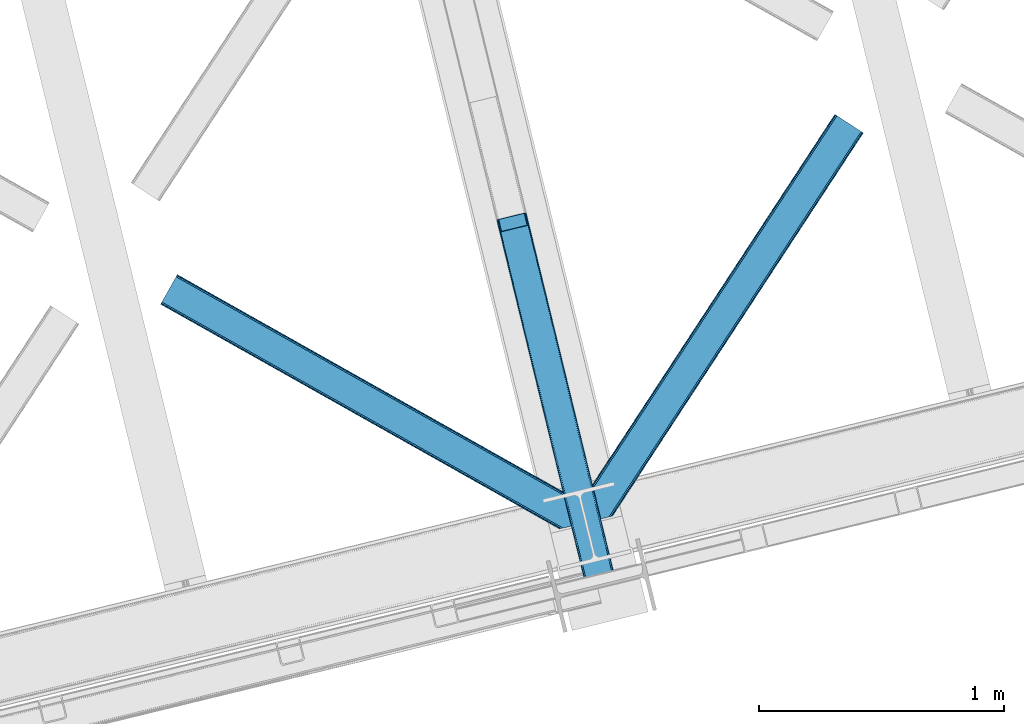
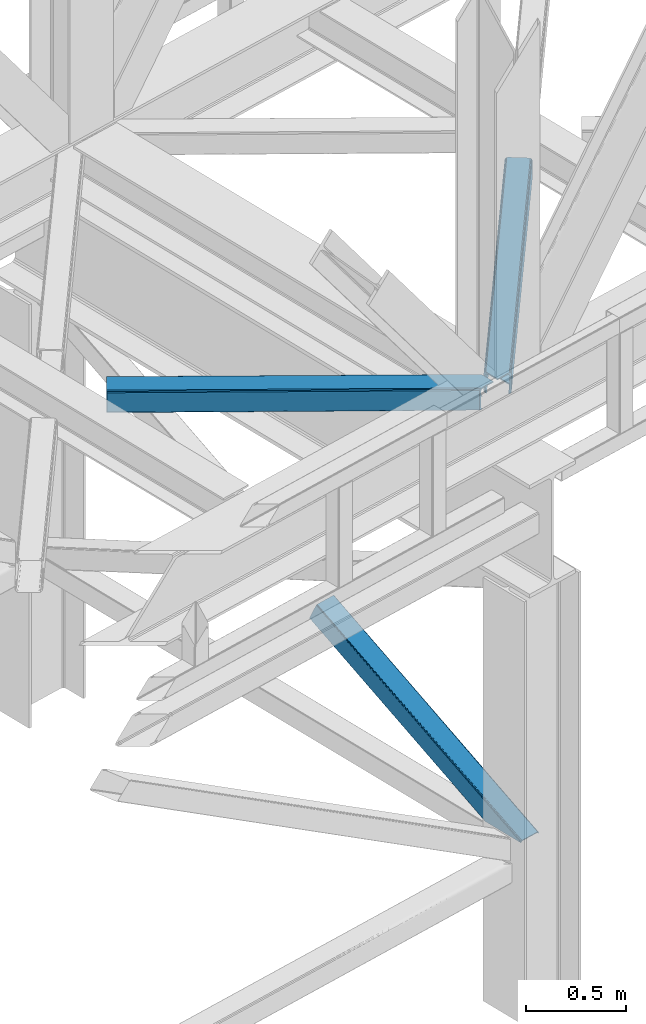
# One storey, part 51 of 92: 3 members.
"""IFC4 building model written with IfcOpenShell, lengths in millimetres."""

from ifc_helpers import new_model, entity, si_unit, converted_unit, derived_unit, direction, frame, origin, place, context, subcontext, project, spatial, triangles, polygons, type_object, element, save


model = new_model("IFC4")

# Units and contexts
model_context = context("Model", 3, precision=0.01, world=origin(), true_north=direction((6.12303176911189e-17, 1.0)))
plan_context = context("Plan", 3, precision=0.01, world=origin(), true_north=direction((6.12303176911189e-17, 1.0)))
body_context = subcontext(model_context, "Body", "Model", "MODEL_VIEW")
ifc_project = project(units=[si_unit("LENGTHUNIT", "METRE", prefix="MILLI"), si_unit("AREAUNIT", "SQUARE_METRE"), si_unit("VOLUMEUNIT", "CUBIC_METRE"), converted_unit("PLANEANGLEUNIT", "DEGREE", entity("IfcRatioMeasure", 0.0174532925199433), si_unit("PLANEANGLEUNIT", "RADIAN"), dimensions=[0, 0, 0, 0, 0, 0, 0]), si_unit("MASSUNIT", "GRAM", prefix="KILO"), derived_unit("MASSDENSITYUNIT", [(si_unit("MASSUNIT", "GRAM", prefix="KILO"), 1), (si_unit("LENGTHUNIT", "METRE"), -3)]), derived_unit("MOMENTOFINERTIAUNIT", [(si_unit("LENGTHUNIT", "METRE"), 4)]), si_unit("TIMEUNIT", "SECOND"), si_unit("FREQUENCYUNIT", "HERTZ"), si_unit("THERMODYNAMICTEMPERATUREUNIT", "DEGREE_CELSIUS"), derived_unit("THERMALTRANSMITTANCEUNIT", [(si_unit("MASSUNIT", "GRAM", prefix="KILO"), 1), (si_unit("THERMODYNAMICTEMPERATUREUNIT", "KELVIN"), -1), (si_unit("TIMEUNIT", "SECOND"), -3)]), derived_unit("VOLUMETRICFLOWRATEUNIT", [(si_unit("LENGTHUNIT", "METRE"), 3), (si_unit("TIMEUNIT", "SECOND"), -1)]), derived_unit("MASSFLOWRATEUNIT", [(si_unit("MASSUNIT", "GRAM", prefix="KILO"), 1), (si_unit("TIMEUNIT", "SECOND"), -1)]), derived_unit("ROTATIONALFREQUENCYUNIT", [(si_unit("TIMEUNIT", "SECOND"), -1)]), si_unit("ELECTRICCURRENTUNIT", "AMPERE"), si_unit("ELECTRICVOLTAGEUNIT", "VOLT"), si_unit("POWERUNIT", "WATT"), si_unit("FORCEUNIT", "NEWTON", prefix="KILO"), si_unit("ILLUMINANCEUNIT", "LUX"), si_unit("LUMINOUSFLUXUNIT", "LUMEN"), si_unit("LUMINOUSINTENSITYUNIT", "CANDELA"), derived_unit("USERDEFINED", [(si_unit("MASSUNIT", "GRAM", prefix="KILO"), -1), (si_unit("LENGTHUNIT", "METRE"), -2), (si_unit("TIMEUNIT", "SECOND"), 3), (si_unit("LUMINOUSFLUXUNIT", "LUMEN"), 1)]), derived_unit("LINEARVELOCITYUNIT", [(si_unit("LENGTHUNIT", "METRE"), 1), (si_unit("TIMEUNIT", "SECOND"), -1)]), si_unit("PRESSUREUNIT", "PASCAL"), derived_unit("USERDEFINED", [(si_unit("LENGTHUNIT", "METRE"), -2), (si_unit("MASSUNIT", "GRAM", prefix="KILO"), 1), (si_unit("TIMEUNIT", "SECOND"), -2)]), derived_unit("LINEARFORCEUNIT", [(si_unit("MASSUNIT", "GRAM", prefix="KILO"), 1), (si_unit("LENGTHUNIT", "METRE"), 1), (si_unit("TIMEUNIT", "SECOND"), -2), (si_unit("LENGTHUNIT", "METRE"), -1)]), derived_unit("PLANARFORCEUNIT", [(si_unit("MASSUNIT", "GRAM", prefix="KILO"), 1), (si_unit("LENGTHUNIT", "METRE"), 1), (si_unit("TIMEUNIT", "SECOND"), -2), (si_unit("LENGTHUNIT", "METRE"), -2)])], contexts=[model_context, plan_context])

# Site, building, storey
site_placement = place(None, origin())
site = spatial("IfcSite", under=ifc_project, at=site_placement, CompositionType="ELEMENT")
building_placement = place(site_placement, origin())
building = spatial("IfcBuilding", under=site, at=building_placement, CompositionType="ELEMENT")
storey_placement = place(building_placement, frame((0.0, 0.0, 15900.0)))
storey = spatial("IfcBuildingStorey", under=building, at=storey_placement, Name="05", CompositionType="ELEMENT", Elevation=15900.0)

# Members
member_type_1 = type_object("IfcMemberType", PredefinedType="BRACE")
member_1_placement = place(storey_placement, frame((-36161.51, 8634.38, 970.5)))
element("IfcMember", 1, at=member_1_placement, inside=storey, type_object=member_type_1, ObjectType="Steel Vertical Brace", PredefinedType="BRACE", context=body_context, shape_type="Tessellation", body=[
    polygons([(310.156875969815, 236.659699185642, 1.04388391264365e-09), (309.042346364978, 243.803283956976, 1.04388391264365e-09), (4.57230123623604, 1492.85694714149, 603.530503671961), (4.2887644560269, 1491.44877039324, 606.301796687595), (309.280773738945, 250.147759710232, 1.04388391264365e-09), (5.99595206162693, 1494.33917875156, 601.181114896124), (310.835859685345, 254.727237524779, 1.05038111541944e-09), (8.34297899943531, 1495.6698088973, 599.611303503947), (313.47085646575, 256.844533416439, 1.04171817838505e-09), (11.256068474249, 1496.64626120118, 599.060059049496), (366.444630080972, 5.74560241384962, 1.00706643024751e-09), (14.4533090982431, 1449.74988433501, 697.72873436856), (411.597614338024, 280.763968808462, 1.04171817838505e-09), (109.382826346531, 1520.5656965932, 599.060059049498), (425.485457020332, 274.460769180909, 1.03522097560926e-09), (485.172065028795, 29.6032616237788, 9.24768528420827e-10), (481.013627176891, 28.5895984014809, 9.24768528420827e-10), (480.116220883526, 33.4542552937189, 9.72414682109957e-10), (423.82846677236, 264.368352065509, 1.03305524135067e-09), (421.530657217855, 271.223499830256, 1.03522097560926e-09), (418.399388388628, 276.746576483304, 1.03738670986786e-09), (414.911367578924, 280.096743671032, 1.04171817838505e-09), (367.88649561307, 1.0136632218215, 9.29099996938021e-10), (363.728057761106, 2.16573425859679e-12, 5.76085312786745e-10), (304.041449752642, 244.857507557118, 1.03522097560926e-09), (302.926920147815, 252.001092328461, 1.04171817838505e-09), (303.165347521768, 258.345568081721, 1.03738670986786e-09), (304.720433468177, 262.925045896267, 1.04604964690225e-09), (307.355430248578, 265.042341787915, 1.04388391264365e-09), (413.254604585991, 290.856385923861, 1.04604964690225e-09), (416.568357826891, 290.189160786438, 1.04604964690225e-09), (420.056378636596, 286.838993598711, 1.04171817838505e-09), (423.187647465814, 281.315916945663, 1.04171817838505e-09), (112.418486893023, 1521.03931504355, 599.611303503942), (115.114566711319, 1520.93799552464, 601.181114896124), (117.060612089108, 1520.27716301477, 603.530503671961), (117.960355258563, 1519.15742327311, 606.301796687595), (128.124899900792, 1477.45853721488, 697.72873436856), (127.841363120579, 1476.05036046663, 700.500027384193), (126.417712295192, 1474.56812885655, 702.849416160034), (124.070685357384, 1473.23749871082, 704.419227552215), (121.15759588257, 1472.26104640693, 704.970472006657), (23.0308380102795, 1448.34161101491, 704.970472006657), (19.9951774637964, 1447.86799256457, 704.419227552218), (17.2990976455005, 1447.96931208348, 702.849416160031), (15.3530522677154, 1448.63014459335, 700.500027384193), (112.866478355636, 1523.16444199718, 595.439190230451), (6.96730401822207, 1497.35039786123, 595.439190230448), (4.05421454341707, 1496.37394555734, 595.990434684895), (1.70718760560436, 1495.04331541162, 597.56024607707), (0.28353678022213, 1493.56108380154, 599.909634852913), (0.0, 1492.15290705329, 602.680927868548), (10.9696570891299, 1447.15113893104, 701.349603187608), (11.8694002585979, 1446.03139918938, 704.120896203242), (13.8154456363916, 1445.37056667951, 706.470284979081), (16.5115254546875, 1445.2692471606, 708.040096371263), (19.5471860011707, 1445.74286561094, 708.591340825705), (125.446360338589, 1471.55690974689, 708.591340825705), (128.359449813402, 1472.53336205077, 708.040096371265), (130.706476751211, 1473.8639921965, 706.470284979079), (132.130127576593, 1475.34622380658, 704.120896203244), (132.413664356815, 1476.75440055483, 701.349603187608), (121.44400726769, 1521.75616867708, 602.680927868548), (120.544264098226, 1522.87590841874, 599.909634852913), (118.598218720428, 1523.53674092861, 597.560246077077), (115.902138902128, 1523.63806044752, 595.990434684897), (375.386682458807, 2.84191311588486, 6.51916727653314), (372.638718264457, 2.17206777061844, 5.2249222388966), (369.890754070107, 1.50222242536393, 3.93067720123624), (368.37332664802, 1.13233343716275, 0.954754934343811), (480.407239661998, 28.4417850297788, 0.783330976602792), (478.425418155208, 27.9586950702373, 3.34344663920135), (476.487815341744, 27.4863838850221, 5.84644062407408), (473.513440331089, 26.761348507908, 6.51916727653314), (485.1720650288, 29.6032616237626, 2.10033831597304), (484.033820990584, 29.325802597071, 5.22492223888794), (482.895576952364, 29.0483435703718, 8.34950616180717), (480.147612758018, 28.3784982251097, 9.64375119945237), (477.399648563664, 27.7086528798498, 10.9379962370932), (371.500474226237, 1.89460874392252, 10.9379962370954), (368.752510031891, 1.22476339866151, 9.64375119945237), (366.004545837554, 0.55491805340375, 8.34950616180934), (364.866301799321, 0.277459026700251, 5.2249222388901), (363.728057761106, 2.16573425859679e-12, 2.10033831597304)], [[[1, 2, 3, 4]], [[2, 5, 6, 3]], [[5, 7, 8, 6]], [[7, 9, 10, 8]], [[11, 1, 4, 12]], [[9, 13, 14, 10]], [[15, 16, 17, 18, 19, 20, 21, 22, 13, 9, 7, 5, 2, 1, 11, 23, 24, 25, 26, 27, 28, 29, 30, 31, 32, 33]], [[47, 48, 49, 50, 51, 52, 53, 54, 55, 56, 57, 58, 59, 60, 61, 62, 63, 64, 65, 66], [10, 14, 34, 35, 36, 37, 38, 39, 40, 41, 42, 43, 44, 45, 46, 12, 4, 3, 6, 8]], [[13, 22, 34, 14]], [[22, 21, 35, 34]], [[21, 20, 36, 35]], [[20, 19, 37, 36]], [[19, 18, 38, 37]], [[44, 67, 68]], [[45, 68, 69]], [[46, 69, 70]], [[46, 11, 12]], [[11, 70, 23]], [[11, 46, 70]], [[69, 46, 45]], [[68, 45, 44]], [[67, 44, 43]], [[71, 18, 17]], [[39, 72, 40]], [[40, 73, 41]], [[73, 74, 42, 41]], [[73, 40, 72]], [[72, 39, 71]], [[39, 18, 71]], [[18, 39, 38]], [[42, 74, 67, 43]], [[16, 75, 76, 77, 78, 79, 80, 81, 82, 83, 84, 24, 23, 70, 69, 68, 67, 74, 73, 72, 71, 17]], [[29, 28, 49, 48]], [[28, 27, 50, 49]], [[27, 26, 51, 50]], [[26, 25, 52, 51]], [[47, 30, 29, 48]], [[15, 33, 64, 63]], [[33, 32, 65, 64]], [[32, 31, 66, 65]], [[31, 30, 47, 66]], [[24, 84, 53, 52, 25]], [[75, 16, 15, 63, 62]], [[53, 83, 54]], [[54, 82, 55]], [[55, 81, 56]], [[56, 80, 57]], [[80, 56, 81]], [[81, 55, 82]], [[82, 54, 83]], [[83, 53, 84]], [[80, 79, 58, 57]], [[59, 79, 78]], [[60, 78, 77]], [[61, 77, 76]], [[62, 76, 75]], [[76, 62, 61]], [[77, 61, 60]], [[78, 60, 59]], [[79, 59, 58]]], closed=True),
])
member_type_2 = type_object("IfcMemberType", PredefinedType="BRACE")
member_2_placement = place(storey_placement, frame((-35805.58, 8895.62, 3511.0)))
element("IfcMember", 2, at=member_2_placement, inside=storey, type_object=member_type_2, ObjectType="Steel Horizontal Brace", PredefinedType="BRACE", context=body_context, shape_type="Tessellation", body=[
    triangles([(109.770043945318, 259.949830627442, 7.52047119140843), (115.030187988283, 238.365682983398, 7.77510681152489), (114.216284179689, 239.946981811523, 8.3320495605476), (108.809637451173, 259.662638854981, 8.52041015625218), (113.637249755862, 239.859777832031, 8.52041015625218), (112.20710449219, 237.677352905273, 8.52041015625218), (91.0339782714873, 232.516621398925, 8.52041015625218), (109.535174560551, 237.025648498535, 9.50058288574292), (90.2619323730469, 232.328260803222, 9.50058288574292), (5.0206237793027, 77.405158996582, 9.50058288574292), (0.625543212896446, 95.4308029174808, 9.50058288574292), (1046.62216186523, 1651.75382995605, 6.99957275390625), (1041.02017822266, 1655.42221069336, 8.3320495605476), (116.699853515631, 231.514938354492, 6.99957275390625), (1036.26930541993, 1658.53132324219, 12.1260040283232), (3.92999267578125, 81.8752349853512, 12.1260040283232), (1033.09740600587, 1660.61026611328, 17.8035644531265), (2.69983520507958, 86.9220199584961, 17.8035644531265), (1031.98352050781, 1661.34045410156, 24.4996673583992), (2.26962890625146, 88.6940048217766, 24.4996673583992), (1122.7547241211, 1601.90454711914, 6.99957275390625), (146.209680175787, 110.459536743165, 6.99957275390625), (1031.98352050781, 1661.34045410156, 115.501089477541), (2.26962890625146, 88.6940048217766, 115.501089477541), (1033.09740600587, 1660.61026611328, 122.196029663086), (2.69983520507958, 86.9220199584961, 122.196029663086), (1036.26930541993, 1658.53132324219, 127.87475280762), (3.92999267578125, 81.8752349853512, 127.87475280762), (1041.02017822266, 1655.42221069336, 131.667544555665), (5.77174072265916, 74.3227890014641, 131.667544555665), (1046.62216186523, 1651.75382995605, 133.000021362306), (7.94370117187646, 65.4140304565426, 133.000021362306), (1027.24194946289, 1664.44491577148, 10.8028289794929), (0.518572998051241, 95.8714736938473, 10.8691040039084), (0.0, 98.0056457519531, 17.5000946044929), (1035.16472167969, 1659.25686035156, 1.33247680664135), (112.260589599609, 249.73533782959, 1.33247680664135), (110.544415283206, 256.772117614746, 5.59500732422021), (109.077062988283, 259.839372253418, 8.31925964355469), (1030.41384887695, 1662.36597290039, 5.12526855468968), (1040.76670532227, 1655.58847961426, 0.0), (114.430224609379, 240.826579284669, 0.0), (1026.12573852539, 1665.17394104004, 17.5000946044929), (1128.61250610352, 1598.06989746094, 0.0), (148.479309082031, 101.147314453125, 0.0), (150.651269531256, 92.2385559082031, 1.33247680664135), (148.507214355472, 101.029298400879, 8.50064392089917), (152.493017578126, 84.686109924316, 5.12526855468968), (153.346453857426, 81.182254028321, 8.50064392089917), (1026.12573852539, 1665.17394104004, 122.500662231447), (0.0, 98.0056457519531, 122.500662231447), (1040.76670532227, 1655.58847961426, 139.999594116212), (1035.16472167969, 1659.25686035156, 138.667117309571), (3.50211181640771, 83.6350112915043, 138.667117309571), (5.674072265625, 74.7256713867191, 139.999594116212), (1030.41384887695, 1662.36597290039, 134.874325561526), (1.66036376953707, 91.1874572753914, 134.874325561526), (1027.24194946289, 1664.44491577148, 129.197927856447), (0.430206298828125, 96.2336608886726, 129.197927856447), (23.8892395019575, 0.0, 139.999594116212), (23.8892395019575, 0.0, 133.000021362306), (1128.61250610352, 1598.06989746094, 139.999594116212), (93.3338378906265, 16.9280364990227, 139.999594116212), (1122.7547241211, 1601.90454711914, 133.000021362306), (83.3786315917969, 14.5008590698235, 133.000021362306), (1143.2534729004, 1588.48443603516, 122.500662231447), (1142.1372619629, 1589.21346130371, 129.197927856447), (118.225341796875, 22.9951080322262, 122.500662231447), (116.330108642578, 22.5335083007813, 129.197927856447), (1138.96536254883, 1591.29124145508, 134.874325561526), (110.935089111328, 21.2178909301765, 134.874325561526), (1134.2144897461, 1594.40151672363, 138.667117309571), (102.861163330082, 19.2499877929695, 138.667117309571), (1143.2534729004, 1588.48443603516, 17.5000946044929), (118.225341796875, 22.9951080322262, 17.5000946044929), (1142.1372619629, 1589.21346130371, 10.8028289794929), (1133.10758056641, 1595.12589111328, 12.1260040283232), (1136.28180541992, 1593.04811096191, 17.8035644531265), (1137.39569091797, 1592.31792297363, 24.4996673583992), (1138.96536254883, 1591.29124145508, 5.12526855468968), (1134.2144897461, 1594.40151672363, 1.33247680664135), (1128.35903320313, 1598.23616638184, 8.3320495605476), (1133.10758056641, 1595.12589111328, 127.87475280762), (1137.39569091797, 1592.31792297363, 115.501089477541), (1136.28180541992, 1593.04811096191, 122.196029663086), (1128.35903320313, 1598.23616638184, 131.667544555665), (92.9036315917983, 16.8228103637703, 131.667544555665), (100.977557373051, 18.7912948608391, 127.87475280762), (106.372576904301, 20.106330871582, 122.196029663086), (108.267810058598, 20.5685119628906, 115.501089477541), (108.267810058598, 20.5685119628906, 24.4996673583992), (100.977557373051, 18.7912948608391, 12.1260040283232), (115.472021484376, 22.32421875, 9.50058288574292), (106.372576904301, 20.106330871582, 17.8035644531265), (96.1987792968794, 17.6262496948239, 9.50058288574292), (115.944085693365, 22.439328002929, 10.8702667236357), (153.060424804688, 80.2392883300781, 9.00061340332104), (152.776721191411, 79.2969039916989, 9.50058288574292), (148.711853027344, 99.8677413940422, 8.8831787109375), (148.602557373051, 99.023606872559, 9.08781738281323), (148.490936279297, 98.1666824340828, 9.29478149414354), (148.381640625004, 97.3231292724613, 9.50058288574292)], [[1, 2, 3], [4, 5, 6], [6, 7, 4], [7, 6, 8], [8, 9, 7], [9, 8, 10], [10, 11, 9], [12, 13, 3], [3, 2, 12], [2, 14, 12], [15, 16, 8], [8, 13, 15], [8, 5, 13], [16, 10, 8], [8, 6, 5], [15, 17, 18], [18, 16, 15], [17, 19, 20], [20, 18, 17], [21, 12, 14], [14, 22, 21], [19, 23, 20], [24, 20, 23], [23, 25, 24], [26, 24, 25], [25, 27, 26], [28, 26, 27], [27, 29, 28], [30, 28, 29], [29, 31, 30], [32, 30, 31], [33, 34, 35], [36, 37, 38], [33, 4, 9], [33, 1, 39], [9, 34, 33], [9, 11, 34], [4, 7, 9], [40, 38, 1], [1, 33, 40], [38, 40, 36], [36, 41, 37], [42, 37, 41], [35, 43, 33], [41, 44, 42], [45, 42, 44], [14, 42, 22], [37, 2, 38], [2, 37, 42], [38, 2, 1], [42, 14, 2], [22, 42, 45], [46, 47, 45], [47, 46, 48], [45, 47, 22], [48, 49, 47], [50, 43, 35], [35, 51, 50], [52, 53, 54], [54, 55, 52], [53, 56, 57], [57, 54, 53], [56, 58, 59], [59, 57, 56], [58, 50, 51], [51, 59, 58], [28, 57, 26], [30, 32, 55], [32, 60, 55], [32, 61, 60], [54, 30, 55], [28, 54, 57], [16, 11, 10], [28, 30, 54], [51, 35, 20], [24, 26, 51], [24, 51, 20], [57, 59, 26], [26, 59, 51], [35, 18, 20], [18, 11, 16], [11, 18, 34], [35, 34, 18], [62, 55, 63], [62, 52, 55], [55, 60, 63], [64, 32, 31], [32, 64, 65], [61, 32, 65], [66, 67, 68], [69, 68, 67], [67, 70, 69], [71, 69, 70], [70, 72, 71], [73, 71, 72], [72, 62, 73], [63, 73, 62], [74, 66, 75], [68, 75, 66], [76, 77, 78], [79, 66, 74], [76, 78, 74], [76, 80, 77], [78, 79, 74], [77, 80, 81], [21, 44, 41], [44, 82, 81], [82, 44, 21], [82, 77, 81], [67, 83, 70], [84, 66, 79], [66, 85, 67], [85, 66, 84], [67, 85, 83], [62, 64, 52], [72, 70, 83], [83, 86, 72], [86, 64, 62], [62, 72, 86], [15, 36, 40], [41, 12, 21], [41, 13, 12], [13, 41, 36], [15, 13, 36], [19, 43, 50], [33, 17, 15], [40, 33, 15], [17, 33, 43], [19, 17, 43], [53, 27, 56], [52, 64, 31], [31, 29, 52], [29, 27, 53], [53, 52, 29], [58, 56, 27], [50, 23, 19], [25, 50, 58], [50, 25, 23], [25, 58, 27], [64, 86, 87], [87, 65, 64], [86, 83, 88], [88, 87, 86], [83, 85, 89], [89, 88, 83], [85, 84, 90], [90, 89, 85], [84, 79, 90], [91, 90, 79], [89, 68, 69], [87, 73, 63], [60, 65, 63], [65, 60, 61], [65, 87, 63], [88, 73, 87], [88, 89, 71], [71, 73, 88], [69, 71, 89], [91, 75, 68], [92, 93, 94], [89, 90, 68], [92, 95, 93], [91, 94, 75], [90, 91, 68], [96, 75, 94], [94, 93, 96], [76, 74, 75], [49, 80, 97], [98, 97, 80], [49, 48, 80], [76, 96, 98], [98, 80, 76], [96, 93, 98], [44, 81, 45], [46, 45, 81], [81, 80, 46], [48, 46, 80], [75, 96, 76], [82, 21, 22], [77, 82, 47], [47, 99, 77], [77, 100, 101], [100, 77, 99], [101, 102, 77], [77, 102, 92], [95, 92, 102], [22, 47, 82], [79, 78, 91], [94, 91, 78], [78, 77, 94], [92, 94, 77], [102, 101, 98], [101, 100, 97], [100, 99, 49], [99, 47, 49], [102, 98, 93], [93, 95, 102]]),
])
member_type_3 = type_object("IfcMemberType", PredefinedType="BRACE")
member_3_placement = place(storey_placement, frame((-37535.62, 8865.52, 3511.0)))
element("IfcMember", 3, at=member_3_placement, inside=storey, type_object=member_type_3, ObjectType="Steel Horizontal Brace", PredefinedType="BRACE", context=body_context, shape_type="Tessellation", body=[
    triangles([(1645.81582031251, 3.74512023925854, 138.667117309571), (1655.3408203125, 6.06707153320349, 139.999594116212), (8.58784790039499, 933.436047363282, 139.999594116212), (5.302001953125, 927.601519775391, 138.667117309571), (1637.74189453125, 1.77721710205151, 134.874325561526), (2.51612548828416, 922.654147338868, 134.874325561526), (1632.346875, 0.462181091308594, 129.197927856447), (0.65577392578416, 919.34853515625, 129.197927856447), (1630.45164184571, 0.0, 122.500662231447), (0.0, 918.188140869141, 122.500662231447), (1630.45164184571, 0.0, 17.5000946044929), (0.0, 918.188140869141, 17.5000946044929), (1706.5725769043, 97.721360778809, 139.999594116212), (1724.78774414063, 22.9951080322262, 139.999594116212), (60.1102844238339, 1024.92581176758, 139.999594116212), (1701.3287109375, 119.229350280762, 129.197927856447), (1700.89850463867, 121.001335144043, 122.500662231447), (68.0446838378921, 1039.01332397461, 129.197927856447), (68.6981323242217, 1040.17488098145, 122.500662231447), (1702.5588684082, 114.182565307618, 134.874325561526), (66.1820068359375, 1035.70887451172, 134.874325561526), (1704.40061645508, 106.63011932373, 138.667117309571), (63.3961303710967, 1030.7615020752, 138.667117309571), (1700.89850463867, 121.001335144043, 17.5000946044929), (68.6981323242217, 1040.17488098145, 17.5000946044929), (0.65577392578416, 919.34853515625, 10.8028289794929), (1633.02822875977, 0.628450012207395, 10.9377044677749), (2.51612548828416, 922.654147338868, 5.12526855468968), (5.302001953125, 927.601519775391, 1.33247680664135), (1569.7995300293, 46.554135131837, 1.33247680664135), (1573.68999023438, 34.8100845336921, 8.52041015625218), (1571.51337890625, 39.517936706543, 5.59500732422021), (1572.28775024414, 36.3396423339855, 7.52047119140843), (1573.35047607422, 35.1804107666012, 8.278564453125), (1572.99003295899, 35.5751541137706, 8.02044067383031), (1572.6272644043, 35.9693161010746, 7.76231689453198), (1633.97700805665, 0.859831237792605, 8.52041015625218), (1567.62756958008, 55.4634750366222, 0.0), (8.58784790039499, 933.436047363282, 0.0), (1533.57848510743, 195.142739868164, 0.0), (60.1102844238339, 1024.92581176758, 0.0), (1566.72994995117, 59.1411575317379, 7.52047119140843), (1567.24852294922, 57.3430114746097, 7.90300598144677), (1567.7856994629, 56.436090087891, 8.1076446533225), (1568.32752685547, 55.5198669433594, 8.31460876464917), (1568.41124267579, 55.37627105713, 8.3471649169951), (1568.86237792969, 54.6129455566406, 8.52041015625218), (1655.15013427735, 6.02056274414099, 8.52041015625218), (5.9507995605527, 928.753775024414, 12.1260040283232), (1647.69942626954, 4.20439453125073, 12.1260040283232), (8.73667602539354, 933.699984741212, 8.3320495605476), (12.0225219726563, 939.535675048828, 6.99957275390625), (1565.35794067383, 64.7751159667969, 6.99957275390625), (1642.30208129883, 2.88819580078234, 17.8035644531265), (4.0904479980527, 925.448162841798, 17.8035644531265), (1640.40684814454, 2.42717742919922, 24.4996673583992), (3.43467407226854, 924.286605834961, 24.4996673583992), (1640.40684814454, 2.42717742919922, 115.501089477541), (3.43467407226854, 924.286605834961, 115.501089477541), (1647.69942626954, 4.20439453125073, 127.87475280762), (1655.77335205078, 6.17229766845776, 131.667544555665), (1642.30208129883, 2.88819580078234, 122.196029663086), (1665.29835205078, 8.49424896240271, 133.000021362306), (1724.78774414063, 22.9951080322262, 133.000021362306), (4.0904479980527, 925.448162841798, 122.196029663086), (5.9507995605527, 928.753775024414, 127.87475280762), (8.73667602539354, 933.699984741212, 131.667544555665), (12.0225219726563, 939.535675048828, 133.000021362306), (1708.84220581055, 88.4097198486324, 133.000021362306), (56.6756103515654, 1018.82734680176, 133.000021362306), (1535.84811401367, 185.830517578126, 6.99957275390625), (56.6756103515654, 1018.82734680176, 6.99957275390625), (68.0446838378921, 1039.01332397461, 10.8028289794929), (62.7496582031308, 1029.60924682617, 12.1260040283232), (64.6100097656308, 1032.91485900879, 17.8035644531265), (65.2634582519531, 1034.0752532959, 24.4996673583992), (66.1820068359375, 1035.70887451172, 5.12526855468968), (63.3961303710967, 1030.7615020752, 1.33247680664135), (59.9614562988281, 1024.66187438965, 8.3320495605476), (62.7496582031308, 1029.60924682617, 127.87475280762), (65.2634582519531, 1034.0752532959, 115.501089477541), (64.6100097656308, 1032.91485900879, 122.196029663086), (59.9614562988281, 1024.66187438965, 131.667544555665), (1703.16813354492, 111.689694213868, 24.4996673583992), (1703.16813354492, 111.689694213868, 115.501089477541), (1706.67024536133, 97.3184783935558, 131.667544555665), (1704.82849731445, 104.870924377441, 127.87475280762), (1703.59833984375, 109.917127990722, 122.196029663086), (1704.82849731445, 104.870924377441, 12.1260040283232), (1706.52839355469, 97.899838256837, 8.52041015625218), (1701.70078125, 117.702699279786, 8.52041015625218), (1703.59833984375, 109.917127990722, 17.8035644531265), (1701.48451538086, 118.590435791017, 10.9365417480476), (1534.47610473633, 191.464476013183, 7.52047119140843), (1529.69267578125, 211.08769683838, 5.59500732422021), (1528.91597900391, 214.265991210938, 7.52047119140843), (1531.4065246582, 204.051498413086, 1.33247680664135), (1529.11596679688, 214.689221191407, 8.22740478515698), (1529.01597290039, 214.477606201172, 7.87393798828271), (1529.90196533204, 214.452026367188, 8.52041015625218), (1534.35053100586, 192.705097961427, 7.85649719238427), (1534.72725219727, 194.649165344239, 8.52041015625218)], [[1, 2, 3], [3, 4, 1], [5, 1, 4], [4, 6, 5], [7, 5, 6], [6, 8, 7], [9, 7, 8], [8, 10, 9], [11, 9, 10], [10, 12, 11], [2, 13, 3], [2, 14, 13], [15, 3, 13], [16, 17, 18], [19, 18, 17], [20, 16, 21], [18, 21, 16], [22, 20, 23], [21, 23, 20], [13, 22, 15], [23, 15, 22], [17, 24, 19], [25, 19, 24], [26, 27, 11], [28, 29, 30], [27, 26, 31], [26, 28, 32], [32, 33, 26], [34, 26, 35], [34, 31, 26], [26, 36, 35], [26, 33, 36], [31, 37, 27], [30, 32, 28], [38, 30, 29], [29, 39, 38], [11, 12, 26], [40, 38, 39], [39, 41, 40], [33, 42, 43], [36, 43, 44], [35, 44, 45], [34, 46, 47], [34, 45, 46], [47, 31, 34], [45, 34, 35], [44, 35, 36], [43, 36, 33], [48, 37, 47], [31, 47, 37], [49, 50, 47], [47, 51, 49], [47, 46, 51], [50, 48, 47], [52, 43, 42], [51, 46, 45], [45, 52, 51], [45, 44, 52], [43, 52, 44], [42, 53, 52], [54, 50, 49], [49, 55, 54], [56, 54, 55], [55, 57, 56], [58, 56, 59], [57, 59, 56], [60, 61, 1], [5, 60, 1], [5, 7, 62], [60, 5, 62], [62, 7, 9], [61, 2, 1], [14, 63, 64], [14, 2, 63], [61, 63, 2], [62, 9, 58], [56, 11, 54], [9, 56, 58], [11, 27, 54], [9, 11, 56], [37, 54, 27], [50, 54, 37], [48, 50, 37], [62, 58, 65], [59, 65, 58], [60, 62, 66], [65, 66, 62], [61, 60, 67], [66, 67, 60], [63, 61, 68], [67, 68, 61], [69, 63, 68], [63, 69, 64], [68, 70, 69], [53, 71, 52], [72, 52, 71], [73, 74, 75], [76, 19, 25], [73, 75, 25], [73, 77, 74], [75, 76, 25], [74, 77, 78], [72, 41, 39], [41, 79, 78], [79, 41, 72], [79, 74, 78], [18, 80, 21], [81, 19, 76], [19, 82, 18], [82, 19, 81], [18, 82, 80], [15, 70, 3], [23, 21, 80], [80, 83, 23], [83, 70, 15], [15, 23, 83], [49, 29, 28], [39, 52, 72], [39, 51, 52], [51, 39, 29], [49, 51, 29], [57, 12, 10], [26, 55, 49], [28, 26, 49], [55, 26, 12], [57, 55, 12], [4, 66, 6], [3, 70, 68], [68, 67, 3], [67, 66, 4], [4, 3, 67], [8, 6, 66], [10, 59, 57], [65, 10, 8], [10, 65, 59], [65, 8, 66], [84, 85, 76], [81, 76, 85], [86, 69, 70], [70, 83, 86], [87, 86, 83], [83, 80, 87], [88, 87, 80], [80, 82, 88], [85, 88, 82], [82, 81, 85], [87, 20, 22], [89, 90, 91], [20, 87, 88], [86, 87, 22], [86, 13, 69], [14, 69, 13], [69, 14, 64], [86, 22, 13], [24, 17, 84], [91, 92, 89], [92, 24, 84], [93, 92, 91], [93, 24, 92], [17, 85, 84], [88, 16, 20], [17, 16, 88], [85, 17, 88], [40, 71, 53], [94, 95, 96], [40, 94, 71], [94, 97, 95], [94, 40, 97], [38, 40, 53], [42, 38, 53], [32, 42, 33], [42, 30, 38], [42, 32, 30], [73, 25, 24], [98, 99, 77], [96, 77, 99], [96, 95, 77], [73, 93, 100], [100, 77, 73], [100, 98, 77], [93, 91, 100], [78, 77, 95], [97, 40, 41], [41, 78, 97], [95, 97, 78], [24, 93, 73], [72, 71, 94], [94, 79, 72], [101, 102, 79], [79, 94, 101], [74, 79, 102], [90, 89, 102], [74, 102, 89], [92, 84, 75], [76, 75, 84], [89, 92, 74], [75, 74, 92], [101, 94, 99], [102, 101, 99], [91, 90, 102], [102, 100, 91]]),
])

save(model, "model.ifc")
